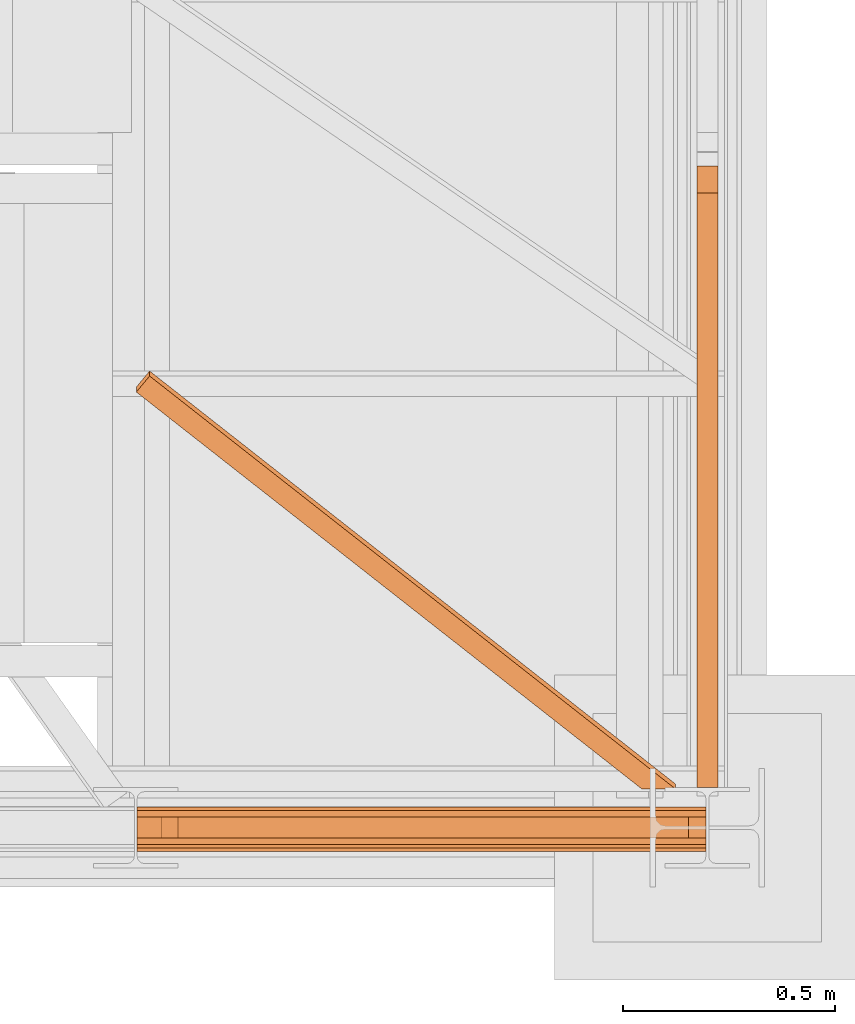
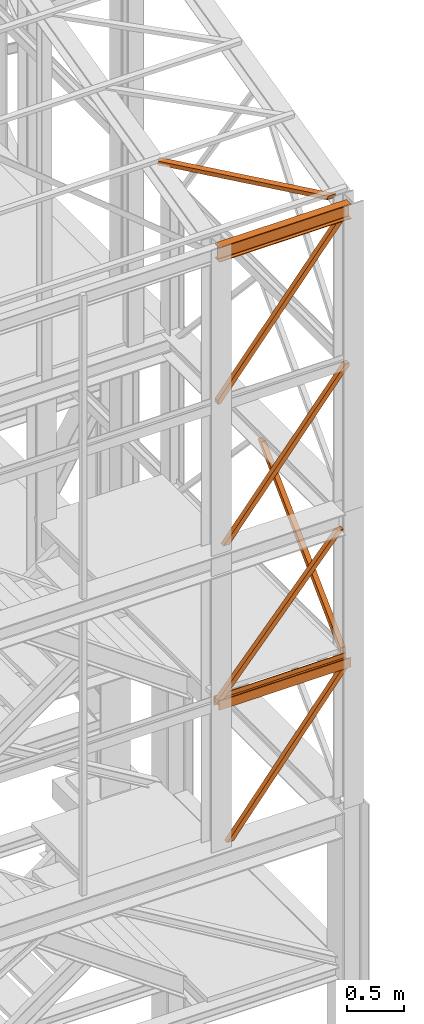
# One storey, part 48 of 208: 8 proxies.
"""IFC2X3 building model written with IfcOpenShell, lengths in millimetres."""

from ifc_helpers import new_model, entity, si_unit, converted_unit, frame, origin, origin_with_axes, place, context, subcontext, project, spatial, faceted_brep, element, save


model = new_model("IFC2X3")

# Units and contexts
model_context = context("Model", 3, precision=1e-05, world=origin())
plan_context = context("Plan", 3, precision=1e-05, world=origin())
body_context = subcontext(model_context, "Body", "Model", "MODEL_VIEW")
ifc_project = project(units=[si_unit("LENGTHUNIT", "METRE", prefix="MILLI"), converted_unit("PLANEANGLEUNIT", "DEGREE", entity("IfcPlaneAngleMeasure", 0.0174532925199433), si_unit("PLANEANGLEUNIT", "RADIAN"), dimensions=[0, 0, 0, 0, 0, 0, 0]), si_unit("AREAUNIT", "SQUARE_METRE"), si_unit("VOLUMEUNIT", "CUBIC_METRE")], contexts=[model_context, plan_context])

# Building, storey
building_placement = place(None, origin())
building = spatial("IfcBuilding", under=ifc_project, at=building_placement, CompositionType="COMPLEX")
storey_placement = place(building_placement, origin_with_axes())
storey = spatial("IfcBuildingStorey", under=building, at=storey_placement, Name="Geschoss", CompositionType="ELEMENT")

# Proxies
proxy_1_placement = place(storey_placement, frame((5409.555422962857, -25197.57439069041, 8496.989995894723), z_axis=(0.0, 0.0, 1.0), x_axis=(1.0, 0.0, 0.0)))
element("IfcBuildingElementProxy", 1, at=proxy_1_placement, inside=storey, context=body_context, shape_type="Brep", body=[
    faceted_brep([(0.009999999999308784, 50.01000074505646, 0.01000000000021828), (1244.693738884314, 50.01000074505646, 1530.51000485033), (1244.693738884314, 0.00999999999839929, 1530.51000485033), (0.01000000000112777, 0.00999999999839929, 0.01000000000021828), (64.45727517743671, 50.01000074505646, 0.01000000000021828), (1285.459545498749, 50.01000074505646, 1501.390569432124), (1285.459545498749, 50.01000074505646, 1530.51000485033), (1244.693738884314, 50.01000074505646, 1530.51000485033), (0.009999999999308784, 50.01000074505646, 0.01000000000021828), (64.45727517743671, 0.00999999999839929, 0.01000000000021828), (1285.45954549875, 0.00999999999839929, 1501.390569432124), (1285.459545498749, 50.01000074505646, 1501.390569432124), (64.45727517743671, 50.01000074505646, 0.01000000000021828), (0.01000000000112777, 0.00999999999839929, 0.01000000000021828), (1244.693738884314, 0.00999999999839929, 1530.51000485033), (1285.45954549875, 0.00999999999839929, 1530.510004850332), (1285.45954549875, 0.00999999999839929, 1501.390569432124), (64.45727517743671, 0.00999999999839929, 0.01000000000021828), (1244.693738884314, 0.00999999999839929, 1530.51000485033), (1244.693738884314, 50.01000074505646, 1530.51000485033), (1285.459545498749, 50.01000074505646, 1530.51000485033), (1285.45954549875, 0.00999999999839929, 1530.510004850332), (1285.459545498749, 50.01000074505646, 1530.51000485033), (1285.459545498749, 50.01000074505646, 1501.390569432124), (1285.45954549875, 0.00999999999839929, 1501.390569432124), (1285.45954549875, 0.00999999999839929, 1530.510004850332), (0.009999999999308784, 50.01000074505646, 0.01000000000021828), (0.01000000000112777, 0.00999999999839929, 0.01000000000021828), (64.45727517743671, 0.00999999999839929, 0.01000000000021828), (64.45727517743671, 50.01000074505646, 0.01000000000021828)], [[[0, 1, 2, 3]], [[4, 5, 6, 7, 8]], [[9, 10, 11, 12]], [[13, 14, 15, 16, 17]], [[18, 19, 20, 21]], [[22, 23, 24, 25]], [[26, 27, 28, 29]]], orient=[[False], [False], [False], [False], [False], [False], [False]]),
])
proxy_2_placement = place(storey_placement, frame((5351.504968595718, -25197.57439069041, 10044.49000051408), z_axis=(0.0, 0.0, 1.0), x_axis=(1.0, 0.0, 0.0)))
element("IfcBuildingElementProxy", 2, at=proxy_2_placement, inside=storey, context=body_context, shape_type="Brep", body=[
    faceted_brep([(0.01000000000112777, 0.00999999999839929, 41.12943667735271), (0.01000000000021828, 50.01000074505646, 41.12943667735271), (1220.994077882662, 50.01000074505646, 1542.487636147871), (1220.994077882662, 0.00999999999839929, 1542.487636147871), (0.01000000000021828, 50.01000074505646, 41.12943667735271), (0.01000000000021828, 50.01000074505646, 0.01000000000021828), (31.01676944585506, 50.01000074505646, 0.01000000000021828), (1285.459539439544, 50.01000074505646, 1542.509998658894), (1226.759995164574, 50.01000074505646, 1542.509998658894), (1220.994077882662, 50.01000074505646, 1542.487636147871), (31.01676944585506, 50.01000074505646, 0.01000000000021828), (31.01676944585506, 0.00999999999839929, 0.01000000000021828), (1285.459539439544, 0.00999999999839929, 1542.509998658894), (1285.459539439544, 50.01000074505646, 1542.509998658894), (0.01000000000021828, 0.00999999999839929, 0.01000000000021828), (0.01000000000112777, 0.00999999999839929, 41.12943667735271), (1220.994077882662, 0.00999999999839929, 1542.487636147871), (1226.759995164574, 0.00999999999839929, 1542.509998658894), (1285.459539439544, 0.00999999999839929, 1542.509998658894), (31.01676944585506, 0.00999999999839929, 0.01000000000021828), (1226.759995164574, 0.00999999999839929, 1542.509998658894), (1226.759995164574, 50.01000074505646, 1542.509998658894), (1285.459539439544, 50.01000074505646, 1542.509998658894), (1285.459539439544, 0.00999999999839929, 1542.509998658894), (1226.759995164574, 50.01000074505646, 1542.509998658894), (1226.759995164574, 0.00999999999839929, 1542.509998658894), (1220.994077882662, 0.00999999999839929, 1542.487636147871), (1220.994077882662, 50.01000074505646, 1542.487636147871), (0.01000000000021828, 50.01000074505646, 0.01000000000021828), (0.01000000000021828, 0.00999999999839929, 0.01000000000021828), (31.01676944585506, 0.00999999999839929, 0.01000000000021828), (31.01676944585506, 50.01000074505646, 0.01000000000021828), (0.01000000000021828, 50.01000074505646, 41.12943667735271), (0.01000000000112777, 0.00999999999839929, 41.12943667735271), (0.01000000000021828, 0.00999999999839929, 0.01000000000021828), (0.01000000000021828, 50.01000074505646, 0.01000000000021828)], [[[0, 1, 2, 3]], [[4, 5, 6, 7, 8, 9]], [[10, 11, 12, 13]], [[14, 15, 16, 17, 18, 19]], [[20, 21, 22, 23]], [[24, 25, 26, 27]], [[28, 29, 30, 31]], [[32, 33, 34, 35]]], orient=[[False], [False], [False], [False], [False], [False], [False], [False]]),
])
proxy_3_placement = place(storey_placement, frame((5351.504968595722, -25220.57438993343, 6759.989999254943), z_axis=(0.0, 0.0, 1.0), x_axis=(1.0, 0.0, 0.0)))
element("IfcBuildingElementProxy", 3, at=proxy_3_placement, inside=storey, context=body_context, shape_type="Brep", body=[
    faceted_brep([(0.01000000000021828, 88.0099999999984, 0.01000000000021828), (0.01000000000021828, 96.0099999999984, 0.01000000000021828), (0.01000000000021828, 96.0099999999984, 100.0100000000002), (0.01000000000021828, 88.0099999999984, 100.0100000000002), (0.01000000000021828, 88.0099999999984, 52.51000000000022), (0.01000000000021828, 8.0099999999984, 52.51000000000022), (0.01000000000021828, 8.0099999999984, 100.0100000000002), (0.01000000000021828, 0.00999999999839929, 100.0100000000002), (0.01000000000021828, 0.00999999999839929, 0.01000000000021828), (0.01000000000021828, 8.0099999999984, 0.01000000000021828), (0.01000000000021828, 8.0099999999984, 47.51000000000022), (0.01000000000021828, 88.0099999999984, 47.51000000000022), (0.01000000000021828, 96.0099999999984, 0.01000000000021828), (0.01000000000021828, 88.0099999999984, 0.01000000000021828), (1343.509999865888, 88.0099999999984, 0.01000000000021828), (1343.509999865888, 96.0099999999984, 0.01000000000021828), (0.01000000000021828, 96.0099999999984, 100.0100000000002), (0.01000000000021828, 96.0099999999984, 0.01000000000021828), (1343.509999865888, 96.0099999999984, 0.01000000000021828), (1343.509999865888, 96.0099999999984, 100.0100000000002), (0.01000000000021828, 88.0099999999984, 100.0100000000002), (0.01000000000021828, 96.0099999999984, 100.0100000000002), (1343.509999865888, 96.0099999999984, 100.0100000000002), (1343.509999865888, 88.0099999999984, 100.0100000000002), (0.01000000000021828, 88.0099999999984, 52.51000000000022), (0.01000000000021828, 88.0099999999984, 100.0100000000002), (1343.509999865888, 88.0099999999984, 100.0100000000002), (1343.509999865888, 88.0099999999984, 52.51000000000022), (0.01000000000021828, 8.0099999999984, 52.51000000000022), (0.01000000000021828, 88.0099999999984, 52.51000000000022), (1343.509999865888, 88.0099999999984, 52.51000000000022), (1343.509999865888, 8.0099999999984, 52.51000000000022), (0.01000000000021828, 8.0099999999984, 100.0100000000002), (0.01000000000021828, 8.0099999999984, 52.51000000000022), (1343.509999865888, 8.0099999999984, 52.51000000000022), (1343.509999865888, 8.0099999999984, 100.0100000000002), (0.01000000000021828, 0.00999999999839929, 100.0100000000002), (0.01000000000021828, 8.0099999999984, 100.0100000000002), (1343.509999865888, 8.0099999999984, 100.0100000000002), (1343.509999865888, 0.00999999999839929, 100.0100000000002), (0.01000000000021828, 0.00999999999839929, 0.01000000000021828), (0.01000000000021828, 0.00999999999839929, 100.0100000000002), (1343.509999865888, 0.00999999999839929, 100.0100000000002), (1343.509999865888, 0.00999999999839929, 0.01000000000021828), (0.01000000000021828, 8.0099999999984, 0.01000000000021828), (0.01000000000021828, 0.00999999999839929, 0.01000000000021828), (1343.509999865888, 0.00999999999839929, 0.01000000000021828), (1343.509999865888, 8.0099999999984, 0.01000000000021828), (0.01000000000021828, 8.0099999999984, 47.51000000000022), (0.01000000000021828, 8.0099999999984, 0.01000000000021828), (1343.509999865888, 8.0099999999984, 0.01000000000021828), (1343.509999865888, 8.0099999999984, 47.51000000000022), (0.01000000000021828, 88.0099999999984, 47.51000000000022), (0.01000000000021828, 8.0099999999984, 47.51000000000022), (1343.509999865888, 8.0099999999984, 47.51000000000022), (1343.509999865888, 88.0099999999984, 47.51000000000022), (0.01000000000021828, 88.0099999999984, 0.01000000000021828), (0.01000000000021828, 88.0099999999984, 47.51000000000022), (1343.509999865888, 88.0099999999984, 47.51000000000022), (1343.509999865888, 88.0099999999984, 0.01000000000021828), (1343.509999865888, 88.0099999999984, 0.01000000000021828), (1343.509999865888, 88.0099999999984, 47.51000000000022), (1343.509999865888, 8.0099999999984, 47.51000000000022), (1343.509999865888, 8.0099999999984, 0.01000000000021828), (1343.509999865888, 0.00999999999839929, 0.01000000000021828), (1343.509999865888, 0.00999999999839929, 100.0100000000002), (1343.509999865888, 8.0099999999984, 100.0100000000002), (1343.509999865888, 8.0099999999984, 52.51000000000022), (1343.509999865888, 88.0099999999984, 52.51000000000022), (1343.509999865888, 88.0099999999984, 100.0100000000002), (1343.509999865888, 96.0099999999984, 100.0100000000002), (1343.509999865888, 96.0099999999984, 0.01000000000021828)], [[[0, 1, 2, 3, 4, 5, 6, 7, 8, 9, 10, 11]], [[12, 13, 14, 15]], [[16, 17, 18, 19]], [[20, 21, 22, 23]], [[24, 25, 26, 27]], [[28, 29, 30, 31]], [[32, 33, 34, 35]], [[36, 37, 38, 39]], [[40, 41, 42, 43]], [[44, 45, 46, 47]], [[48, 49, 50, 51]], [[52, 53, 54, 55]], [[56, 57, 58, 59]], [[60, 61, 62, 63, 64, 65, 66, 67, 68, 69, 70, 71]]], orient=[[False], [False], [False], [False], [False], [False], [False], [False], [False], [False], [False], [False], [False], [False]]),
])
proxy_4_placement = place(storey_placement, frame((5448.254970018782, -25197.57439069041, 5284.990005364413), z_axis=(0.0, 0.0, 1.0), x_axis=(1.0, 0.0, 0.0)))
element("IfcBuildingElementProxy", 4, at=proxy_4_placement, inside=storey, context=body_context, shape_type="Brep", body=[
    faceted_brep([(0.01000000000021828, 50.01000074505646, 0.01000000000112777), (1205.994191828392, 50.01000074505646, 1510.509994121497), (1205.994191828392, 0.00999999999839929, 1510.509994121497), (0.01000000000112777, 0.00999999999839929, 0.01000000000021828), (64.45727517743671, 50.01000074505646, 0.01000000000112777), (1246.759998442828, 50.01000074505646, 1481.39055870329), (1246.759998442828, 50.01000074505646, 1510.509994121497), (1205.994191828392, 50.01000074505646, 1510.509994121497), (0.01000000000021828, 50.01000074505646, 0.01000000000112777), (64.45727517743671, 0.00999999999839929, 0.01000000000112777), (1246.759998442829, 0.00999999999839929, 1481.390558703291), (1246.759998442828, 50.01000074505646, 1481.39055870329), (64.45727517743671, 50.01000074505646, 0.01000000000112777), (0.01000000000112777, 0.00999999999839929, 0.01000000000021828), (1205.994191828392, 0.00999999999839929, 1510.509994121497), (1246.759998442829, 0.00999999999839929, 1510.509994121498), (1246.759998442829, 0.00999999999839929, 1481.390558703291), (64.45727517743671, 0.00999999999839929, 0.01000000000112777), (1205.994191828392, 0.00999999999839929, 1510.509994121497), (1205.994191828392, 50.01000074505646, 1510.509994121497), (1246.759998442828, 50.01000074505646, 1510.509994121497), (1246.759998442829, 0.00999999999839929, 1510.509994121498), (1246.759998442828, 50.01000074505646, 1510.509994121497), (1246.759998442828, 50.01000074505646, 1481.39055870329), (1246.759998442829, 0.00999999999839929, 1481.390558703291), (1246.759998442829, 0.00999999999839929, 1510.509994121498), (0.01000000000021828, 50.01000074505646, 0.01000000000112777), (0.01000000000112777, 0.00999999999839929, 0.01000000000021828), (64.45727517743671, 0.00999999999839929, 0.01000000000112777), (64.45727517743671, 50.01000074505646, 0.01000000000112777)], [[[0, 1, 2, 3]], [[4, 5, 6, 7, 8]], [[9, 10, 11, 12]], [[13, 14, 15, 16, 17]], [[18, 19, 20, 21]], [[22, 23, 24, 25]], [[26, 27, 28, 29]]], orient=[[False], [False], [False], [False], [False], [False], [False]]),
])
proxy_5_placement = place(storey_placement, frame((5351.504968595721, -25197.57439069041, 6812.489999254942), z_axis=(0.0, 0.0, 1.0), x_axis=(1.0, 0.0, 0.0)))
element("IfcBuildingElementProxy", 5, at=proxy_5_placement, inside=storey, context=body_context, shape_type="Brep", body=[
    faceted_brep([(0.01000000000112777, 0.00999999999839929, 41.12943667735271), (0.01000000000021828, 50.01000074505646, 41.12943667735271), (1226.759995164573, 50.01000074505646, 1449.577578879704), (1226.759995164573, 0.00999999999839929, 1449.577578879704), (0.01000000000021828, 50.01000074505646, 41.12943667735271), (0.01000000000021828, 50.01000074505646, 0.01000000000021828), (31.01676944585506, 50.01000074505646, 0.01000000000112777), (1285.459539439544, 50.01000074505646, 1442.509998658894), (1226.759995164574, 50.01000074505646, 1442.509998658894), (1226.759995164573, 50.01000074505646, 1449.577578879704), (31.01676944585506, 50.01000074505646, 0.01000000000112777), (31.01676944585506, 0.00999999999839929, 0.01000000000112777), (1285.459539439544, 0.00999999999839929, 1442.509998658894), (1285.459539439544, 50.01000074505646, 1442.509998658894), (0.01000000000021828, 0.00999999999839929, 0.01000000000021828), (0.01000000000112777, 0.00999999999839929, 41.12943667735271), (1226.759995164573, 0.00999999999839929, 1449.577578879704), (1226.759995164574, 0.00999999999839929, 1442.509998658894), (1285.459539439544, 0.00999999999839929, 1442.509998658894), (31.01676944585506, 0.00999999999839929, 0.01000000000112777), (1226.759995164574, 0.00999999999839929, 1442.509998658894), (1226.759995164574, 50.01000074505646, 1442.509998658894), (1285.459539439544, 50.01000074505646, 1442.509998658894), (1285.459539439544, 0.00999999999839929, 1442.509998658894), (1226.759995164574, 50.01000074505646, 1442.509998658894), (1226.759995164574, 0.00999999999839929, 1442.509998658894), (1226.759995164573, 0.00999999999839929, 1449.577578879704), (1226.759995164573, 50.01000074505646, 1449.577578879704), (0.01000000000021828, 50.01000074505646, 0.01000000000021828), (0.01000000000021828, 0.00999999999839929, 0.01000000000021828), (31.01676944585506, 0.00999999999839929, 0.01000000000112777), (31.01676944585506, 50.01000074505646, 0.01000000000112777), (0.01000000000021828, 50.01000074505646, 41.12943667735271), (0.01000000000112777, 0.00999999999839929, 41.12943667735271), (0.01000000000021828, 0.00999999999839929, 0.01000000000021828), (0.01000000000021828, 50.01000074505646, 0.01000000000021828)], [[[0, 1, 2, 3]], [[4, 5, 6, 7, 8, 9]], [[10, 11, 12, 13]], [[14, 15, 16, 17, 18, 19]], [[20, 21, 22, 23]], [[24, 25, 26, 27]], [[28, 29, 30, 31]], [[32, 33, 34, 35]]], orient=[[False], [False], [False], [False], [False], [False], [False], [False]]),
])
proxy_6_placement = place(storey_placement, frame((6673.254968156138, -25077.57437538435, 6812.489999254944), z_axis=(0.0, 0.0, 1.0), x_axis=(1.0, 0.0, 0.0)))
element("IfcBuildingElementProxy", 6, at=proxy_6_placement, inside=storey, context=body_context, shape_type="Brep", body=[
    faceted_brep([(50.01000074505828, 0.01000000000203727, 71.50990716364959), (0.01000000000021828, 0.01000000000203727, 71.50990716364777), (0.009999999999308784, 1404.126463695793, 1442.509998658892), (50.01000074505737, 1404.126463695793, 1442.509998658892), (50.01000074505828, 7.230990578147612, 0.1025547097015078), (50.01000074505828, 0.01000000000203727, 0.009999999999308784), (50.01000074505828, 0.01000000000203727, 71.50990716364959), (50.01000074505737, 1404.126463695793, 1442.509998658892), (50.01000074505737, 1467.509985364497, 1442.509998658892), (0.01000000000021828, 7.230990578147612, 0.1025547097015078), (50.01000074505828, 7.230990578147612, 0.1025547097015078), (50.01000074505737, 1467.509985364497, 1442.509998658892), (0.009999999999308784, 1467.509985364497, 1442.50999865889), (0.01000000000021828, 0.01000000000203727, 71.50990716364777), (0.01000000000021828, 0.01000000000203727, 0.009999999999308784), (0.01000000000021828, 7.230990578147612, 0.1025547097015078), (0.009999999999308784, 1467.509985364497, 1442.50999865889), (0.009999999999308784, 1404.126463695793, 1442.509998658892), (0.01000000000021828, 0.01000000000203727, 0.009999999999308784), (50.01000074505828, 0.01000000000203727, 0.009999999999308784), (50.01000074505828, 7.230990578147612, 0.1025547097015078), (0.01000000000021828, 7.230990578147612, 0.1025547097015078), (0.01000000000021828, 0.01000000000203727, 71.50990716364777), (50.01000074505828, 0.01000000000203727, 71.50990716364959), (50.01000074505828, 0.01000000000203727, 0.009999999999308784), (0.01000000000021828, 0.01000000000203727, 0.009999999999308784), (50.01000074505737, 1404.126463695793, 1442.509998658892), (0.009999999999308784, 1404.126463695793, 1442.509998658892), (0.009999999999308784, 1467.509985364497, 1442.50999865889), (50.01000074505737, 1467.509985364497, 1442.509998658892)], [[[0, 1, 2, 3]], [[4, 5, 6, 7, 8]], [[9, 10, 11, 12]], [[13, 14, 15, 16, 17]], [[18, 19, 20, 21]], [[22, 23, 24, 25]], [[26, 27, 28, 29]]], orient=[[False], [False], [False], [False], [False], [False], [False]]),
])
proxy_7_placement = place(storey_placement, frame((5351.504968595714, -25229.57439221033, 11599.98999433756), z_axis=(0.0, 0.0, 1.0), x_axis=(1.0, 0.0, 0.0)))
element("IfcBuildingElementProxy", 7, at=proxy_7_placement, inside=storey, context=body_context, shape_type="Brep", body=[
    faceted_brep([(1343.509999865893, 82.0100022649749, 7.40999860525335), (1343.509999865893, 82.0100022649749, 0.01000000000203727), (1343.509999865893, 0.00999999999839929, 0.01000000000203727), (1343.509999865893, 0.00999999999839929, 7.40999860525335), (1343.509999865893, 29.51000017881233, 7.40999860525335), (1343.509999865893, 34.16790572762329, 8.342274854185234), (1343.509999865893, 37.57772680207927, 11.7521001195928), (1343.509999865893, 38.51000095553536, 16.41000194311346), (1343.509999865893, 38.51000095553536, 143.6100093817731), (1343.509999865893, 37.57772680207927, 148.2679112052938), (1343.509999865893, 34.16790572762329, 151.6777364707014), (1343.509999865893, 29.51000017881233, 152.6100127196332), (1343.509999865893, 0.00999999999839929, 152.6100127196332), (1343.509999865893, 0.00999999999839929, 160.0100113248845), (1343.509999865893, 82.0100022649749, 160.0100113248845), (1343.509999865893, 82.0100022649749, 152.6100127196332), (1343.509999865893, 52.51000208616097, 152.6100127196332), (1343.509999865893, 47.85209653735001, 151.6777364707014), (1343.509999865893, 44.44227546289403, 148.2679112052938), (1343.509999865893, 43.51000130943794, 143.6100093817731), (1343.509999865893, 43.51000130943794, 16.41000194311346), (1343.509999865893, 44.44227546289403, 11.7521001195928), (1343.509999865893, 47.85209653735001, 8.342274854185234), (1343.509999865893, 52.51000208616097, 7.40999860525335), (1343.509999865893, 82.0100022649749, 0.01000000000203727), (1343.509999865893, 82.0100022649749, 7.40999860525335), (0.01000000000021828, 82.25026703788535, 7.40999860525335), (0.01000000000021828, 82.25026703788535, 0.01000000000203727), (1343.509999865893, 0.00999999999839929, 0.01000000000203727), (1343.509999865893, 82.0100022649749, 0.01000000000203727), (0.01000000000021828, 82.25026703788535, 0.01000000000203727), (0.01000000000021828, 0.2502647729088494, 0.01000000000021828), (1343.509999865893, 0.00999999999839929, 7.40999860525335), (1343.509999865893, 0.00999999999839929, 0.01000000000203727), (0.01000000000021828, 0.2502647729088494, 0.01000000000021828), (0.01000000000021828, 0.2502647729088494, 7.409998605251531), (1343.509999865893, 29.51000017881233, 7.40999860525335), (1343.509999865893, 0.00999999999839929, 7.40999860525335), (0.01000000000021828, 0.2502647729088494, 7.409998605251531), (0.01000000000021828, 29.75026495172278, 7.40999860525335), (1343.509999865893, 34.16790572762329, 8.342274854185234), (1343.509999865893, 29.51000017881233, 7.40999860525335), (0.01000000000021828, 29.75026495172278, 7.40999860525335), (0.01000000000021828, 34.40817050053374, 8.342274854185234), (1343.509999865893, 37.57772680207927, 11.7521001195928), (1343.509999865893, 34.16790572762329, 8.342274854185234), (0.01000000000021828, 34.40817050053374, 8.342274854185234), (0.01000000000021828, 37.81799157498972, 11.7521001195928), (1343.509999865893, 38.51000095553536, 16.41000194311346), (1343.509999865893, 37.57772680207927, 11.7521001195928), (0.01000000000021828, 37.81799157498972, 11.7521001195928), (0.01000000000021828, 38.75026572844581, 16.41000194311346), (1343.509999865893, 38.51000095553536, 143.6100093817731), (1343.509999865893, 38.51000095553536, 16.41000194311346), (0.01000000000021828, 38.75026572844581, 16.41000194311346), (0.01000000000021828, 38.75026572844581, 143.6100093817731), (1343.509999865893, 37.57772680207927, 148.2679112052938), (1343.509999865893, 38.51000095553536, 143.6100093817731), (0.01000000000021828, 38.75026572844581, 143.6100093817731), (0.01000000000021828, 37.81799157498972, 148.2679112052938), (1343.509999865893, 34.16790572762329, 151.6777364707014), (1343.509999865893, 37.57772680207927, 148.2679112052938), (0.01000000000021828, 37.81799157498972, 148.2679112052938), (0.01000000000021828, 34.40817050053374, 151.6777364707014), (1343.509999865893, 29.51000017881233, 152.6100127196332), (1343.509999865893, 34.16790572762329, 151.6777364707014), (0.01000000000021828, 34.40817050053374, 151.6777364707014), (0.01000000000021828, 29.75026495172278, 152.6100127196332), (1343.509999865893, 0.00999999999839929, 152.6100127196332), (1343.509999865893, 29.51000017881233, 152.6100127196332), (0.01000000000021828, 29.75026495172278, 152.6100127196332), (0.01000000000021828, 0.2502647729088494, 152.6100127196332), (1343.509999865893, 0.00999999999839929, 160.0100113248845), (1343.509999865893, 0.00999999999839929, 152.6100127196332), (0.01000000000021828, 0.2502647729088494, 152.6100127196332), (0.01000000000021828, 0.2502647729088494, 160.0100113248845), (1343.509999865893, 82.0100022649749, 160.0100113248845), (1343.509999865893, 0.00999999999839929, 160.0100113248845), (0.01000000000021828, 0.2502647729088494, 160.0100113248845), (0.01000000000021828, 82.25026703788535, 160.0100113248845), (1343.509999865893, 82.0100022649749, 152.6100127196332), (1343.509999865893, 82.0100022649749, 160.0100113248845), (0.01000000000021828, 82.25026703788535, 160.0100113248845), (0.01000000000021828, 82.25026703788535, 152.6100127196332), (1343.509999865893, 52.51000208616097, 152.6100127196332), (1343.509999865893, 82.0100022649749, 152.6100127196332), (0.01000000000021828, 82.25026703788535, 152.6100127196332), (0.01000000000021828, 52.75026685907142, 152.6100127196332), (1343.509999865893, 47.85209653735001, 151.6777364707014), (1343.509999865893, 52.51000208616097, 152.6100127196332), (0.01000000000021828, 52.75026685907142, 152.6100127196332), (0.01000000000021828, 48.09236131026046, 151.6777364707014), (1343.509999865893, 44.44227546289403, 148.2679112052938), (1343.509999865893, 47.85209653735001, 151.6777364707014), (0.01000000000021828, 48.09236131026046, 151.6777364707014), (0.01000000000112777, 44.68254023580448, 148.2679112052938), (1343.509999865893, 43.51000130943794, 143.6100093817731), (1343.509999865893, 44.44227546289403, 148.2679112052938), (0.01000000000112777, 44.68254023580448, 148.2679112052938), (0.01000000000021828, 43.75026608234839, 143.6100093817731), (1343.509999865893, 43.51000130943794, 16.41000194311346), (1343.509999865893, 43.51000130943794, 143.6100093817731), (0.01000000000021828, 43.75026608234839, 143.6100093817731), (0.01000000000021828, 43.75026608234839, 16.41000194311346), (1343.509999865893, 44.44227546289403, 11.7521001195928), (1343.509999865893, 43.51000130943794, 16.41000194311346), (0.01000000000021828, 43.75026608234839, 16.41000194311346), (0.01000000000021828, 44.68254023580448, 11.7521001195928), (1343.509999865893, 47.85209653735001, 8.342274854185234), (1343.509999865893, 44.44227546289403, 11.7521001195928), (0.01000000000021828, 44.68254023580448, 11.7521001195928), (0.01000000000021828, 48.09236131026046, 8.342274854185234), (1343.509999865893, 52.51000208616097, 7.40999860525335), (1343.509999865893, 47.85209653735001, 8.342274854185234), (0.01000000000021828, 48.09236131026046, 8.342274854185234), (0.01000000000021828, 52.75026685907142, 7.40999860525335), (1343.509999865893, 82.0100022649749, 7.40999860525335), (1343.509999865893, 52.51000208616097, 7.40999860525335), (0.01000000000021828, 52.75026685907142, 7.40999860525335), (0.01000000000021828, 82.25026703788535, 7.40999860525335), (0.01000000000021828, 82.25026703788535, 7.40999860525335), (0.01000000000021828, 52.75026685907142, 7.40999860525335), (0.01000000000021828, 48.09236131026046, 8.342274854185234), (0.01000000000021828, 44.68254023580448, 11.7521001195928), (0.01000000000021828, 43.75026608234839, 16.41000194311346), (0.01000000000021828, 43.75026608234839, 143.6100093817731), (0.01000000000112777, 44.68254023580448, 148.2679112052938), (0.01000000000021828, 48.09236131026046, 151.6777364707014), (0.01000000000021828, 52.75026685907142, 152.6100127196332), (0.01000000000021828, 82.25026703788535, 152.6100127196332), (0.01000000000021828, 82.25026703788535, 160.0100113248845), (0.01000000000021828, 0.2502647729088494, 160.0100113248845), (0.01000000000021828, 0.2502647729088494, 152.6100127196332), (0.01000000000021828, 29.75026495172278, 152.6100127196332), (0.01000000000021828, 34.40817050053374, 151.6777364707014), (0.01000000000021828, 37.81799157498972, 148.2679112052938), (0.01000000000021828, 38.75026572844581, 143.6100093817731), (0.01000000000021828, 38.75026572844581, 16.41000194311346), (0.01000000000021828, 37.81799157498972, 11.7521001195928), (0.01000000000021828, 34.40817050053374, 8.342274854185234), (0.01000000000021828, 29.75026495172278, 7.40999860525335), (0.01000000000021828, 0.2502647729088494, 7.409998605251531), (0.01000000000021828, 0.2502647729088494, 0.01000000000021828), (0.01000000000021828, 82.25026703788535, 0.01000000000203727)], [[[0, 1, 2, 3, 4, 5, 6, 7, 8, 9, 10, 11, 12, 13, 14, 15, 16, 17, 18, 19, 20, 21, 22, 23]], [[24, 25, 26, 27]], [[28, 29, 30, 31]], [[32, 33, 34, 35]], [[36, 37, 38, 39]], [[40, 41, 42, 43]], [[44, 45, 46, 47]], [[48, 49, 50, 51]], [[52, 53, 54, 55]], [[56, 57, 58, 59]], [[60, 61, 62, 63]], [[64, 65, 66, 67]], [[68, 69, 70, 71]], [[72, 73, 74, 75]], [[76, 77, 78, 79]], [[80, 81, 82, 83]], [[84, 85, 86, 87]], [[88, 89, 90, 91]], [[92, 93, 94, 95]], [[96, 97, 98, 99]], [[100, 101, 102, 103]], [[104, 105, 106, 107]], [[108, 109, 110, 111]], [[112, 113, 114, 115]], [[116, 117, 118, 119]], [[120, 121, 122, 123, 124, 125, 126, 127, 128, 129, 130, 131, 132, 133, 134, 135, 136, 137, 138, 139, 140, 141, 142, 143]]], orient=[[False], [False], [False], [False], [False], [False], [False], [False], [False], [False], [False], [False], [False], [False], [False], [False], [False], [False], [False], [False], [False], [False], [False], [False], [False], [False]]),
])
proxy_8_placement = place(storey_placement, frame((5349.557664480543, -25080.97715368805, 11758.07001658348), z_axis=(0.0, 0.0, 1.0), x_axis=(1.0, 0.0, 0.0)))
element("IfcBuildingElementProxy", 8, at=proxy_8_placement, inside=storey, context=body_context, shape_type="Brep", body=[
    faceted_brep([(31.43318462620664, 986.5879088895417, 236.6199846940144), (31.43318462620755, 974.7938431927032, 285.2090782679716), (0.009999999999308784, 936.9993550698855, 276.0351949309552), (0.009999999999308784, 948.7934207667204, 227.4461013569999), (1272.939710584218, 0.01000000000203727, 48.59909357395554), (31.43318462620755, 974.7938431927032, 285.2090782679716), (31.43318462620664, 986.5879088895417, 236.6199846940144), (1272.939710584218, 11.80406569683328, 0.01000000000203727), (1272.939710584218, 11.80406569683328, 0.01000000000203727), (31.43318462620664, 986.5879088895417, 236.6199846940144), (0.009999999999308784, 948.7934207667204, 227.4461013569999), (1193.380619749269, 11.80406569683328, 0.01000000000021828), (1193.380619749269, 11.80406569683328, 0.01000000000021828), (0.009999999999308784, 948.7934207667204, 227.4461013569999), (0.009999999999308784, 936.9993550698855, 276.0351949309552), (1193.380619749268, 0.00999999999839929, 48.59909357395736), (1193.380619749268, 0.00999999999839929, 48.59909357395736), (0.009999999999308784, 936.9993550698855, 276.0351949309552), (31.43318462620755, 974.7938431927032, 285.2090782679716), (1272.939710584218, 0.01000000000203727, 48.59909357395554), (1272.939710584218, 0.01000000000203727, 48.59909357395554), (1272.939710584218, 11.80406569683328, 0.01000000000203727), (1193.380619749269, 11.80406569683328, 0.01000000000021828), (1193.380619749268, 0.00999999999839929, 48.59909357395736)], [[[0, 1, 2, 3]], [[4, 5, 6, 7]], [[8, 9, 10, 11]], [[12, 13, 14, 15]], [[16, 17, 18, 19]], [[20, 21, 22, 23]]], orient=[[False], [False], [False], [False], [False], [False]]),
])

save(model, "model.ifc")
